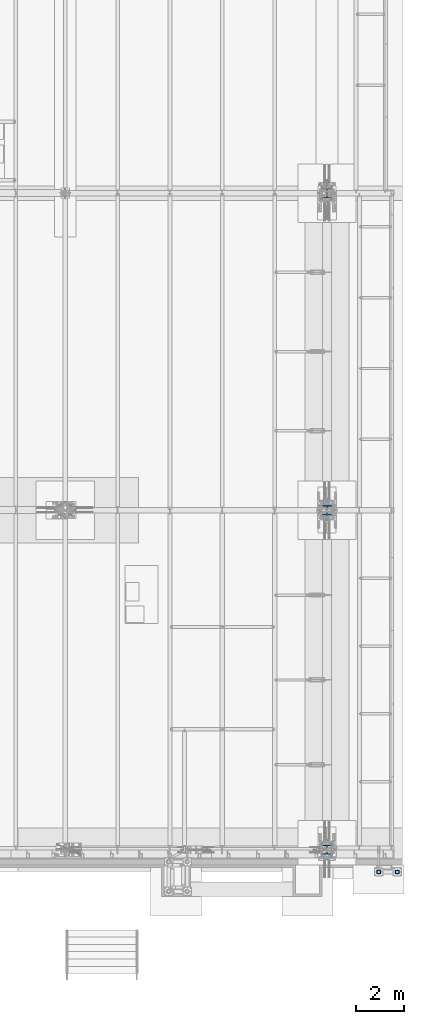
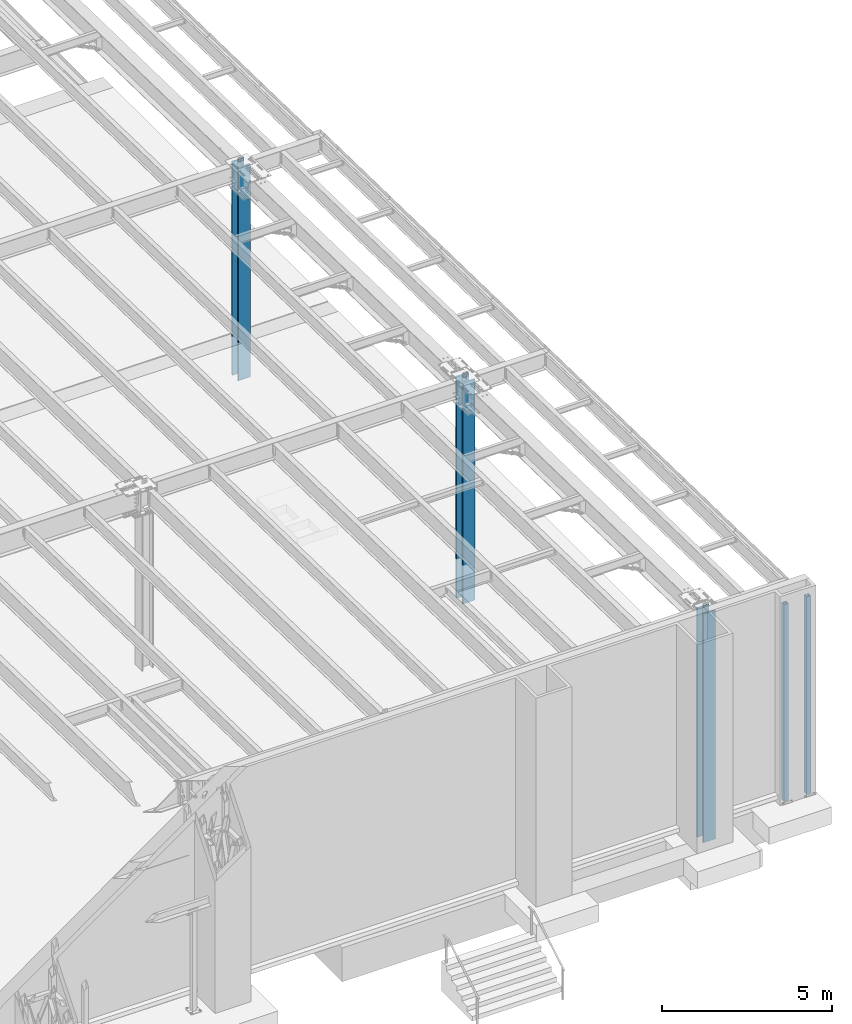
# One storey, part 911 of 1763: 5 columns, 4 elements without a shape of their own.
"""IFC2X3 building model written with IfcOpenShell, lengths in millimetres."""

from ifc_helpers import new_model, si_unit, frame, origin_with_axes, place, context, subcontext, project, spatial, faceted_brep, material, type_object, element, aggregate, save


model = new_model("IFC2X3")

# Units and contexts
model_context = context("Model", 3, precision=1e-05, world=origin_with_axes())
body_context = subcontext(model_context, "Body", "Model", "MODEL_VIEW")
ifc_project = project(units=[si_unit("LENGTHUNIT", "METRE", prefix="MILLI"), si_unit("AREAUNIT", "SQUARE_METRE"), si_unit("VOLUMEUNIT", "CUBIC_METRE"), si_unit("MASSUNIT", "GRAM", prefix="KILO"), si_unit("TIMEUNIT", "SECOND"), si_unit("PLANEANGLEUNIT", "RADIAN"), si_unit("SOLIDANGLEUNIT", "STERADIAN"), si_unit("THERMODYNAMICTEMPERATUREUNIT", "DEGREE_CELSIUS"), si_unit("LUMINOUSINTENSITYUNIT", "LUMEN")], contexts=[model_context])

# Site, building, storey
site_placement = place(None, origin_with_axes())
site = spatial("IfcSite", under=ifc_project, at=site_placement, CompositionType="ELEMENT")
building_placement = place(site_placement, origin_with_axes())
building = spatial("IfcBuilding", under=site, at=building_placement, Name="Undefined", CompositionType="ELEMENT")
storey_placement = place(building_placement, origin_with_axes())
storey = spatial("IfcBuildingStorey", under=building, at=storey_placement, Name="Undefined", CompositionType="ELEMENT", Elevation=0.0)

# Assembly, columns
assembly_1_placement = place(storey_placement, origin_with_axes())
assembly_1 = element("IfcElementAssembly", 1, at=assembly_1_placement, inside=storey, Name="FRAME", AssemblyPlace="NOTDEFINED", PredefinedType="RIGID_FRAME")
ifc_material_1 = material()
column_type_1 = type_object("IfcColumnType", Name="HSS6X6X5/8", PredefinedType="NOTDEFINED")
column_1_placement = place(assembly_1_placement, frame((-21097.3128611525, -14640.6432982799, 5029.2), z_axis=(0.0, 1.0, 0.0), x_axis=(0.0, 0.0, 1.0)))
column_1 = element("IfcColumn", 2, at=column_1_placement, type_object=column_type_1, material=ifc_material_1, Name="COLUMN", ObjectType="HSS6X6X5/8", context=body_context, shape_type="Brep", body=[
    faceted_brep([(63.4999999999973, 60.3249999999971, -60.3250000000007), (63.4999999999973, -60.3249999999971, -60.3250000000007), (7156.45, -60.3249999999971, -60.3250000000007), (7156.45, 60.3249999999971, -60.3250000000007), (63.4999999999973, -60.3249999999971, 60.3250000000007), (7156.45, -60.3249999999971, 60.3250000000007), (63.4999999999973, 60.3249999999971, 60.3250000000007), (7156.45, 60.3249999999971, 60.3250000000007), (63.4999999999973, 76.1999999999971, -76.2000000000007), (63.4999999999973, 76.1999999999971, 76.2000000000007), (7156.45, 76.1999999999971, 76.2000000000007), (7156.45, 76.1999999999971, -76.2000000000007), (63.4999999999973, -76.1999999999971, 76.2000000000007), (7156.45, -76.1999999999971, 76.2000000000007), (63.4999999999973, -76.1999999999971, -76.2000000000007), (7156.45, -76.1999999999971, -76.2000000000007)], [[[0, 1, 2, 3]], [[1, 4, 5, 2]], [[4, 6, 7, 5]], [[6, 0, 3, 7]], [[8, 9, 10, 11]], [[9, 12, 13, 10]], [[12, 14, 15, 13]], [[14, 8, 11, 15]], [[13, 15, 11, 10], [5, 7, 3, 2]], [[14, 12, 9, 8], [6, 4, 1, 0]]]),
])
column_2_placement = place(assembly_1_placement, frame((-21868.838056465, -14640.6432982799, 5029.2), z_axis=(0.0, 1.0, 0.0), x_axis=(0.0, 0.0, 1.0)))
column_2 = element("IfcColumn", 3, at=column_2_placement, type_object=column_type_1, material=ifc_material_1, Name="FRAME", ObjectType="HSS6X6X5/8", context=body_context, shape_type="Brep", body=[
    faceted_brep([(63.4999999999973, 60.3249999999971, -60.3250000000007), (63.4999999999973, -60.3249999999971, -60.3250000000007), (7156.45, -60.3249999999971, -60.3250000000007), (7156.45, 60.3249999999971, -60.3250000000007), (63.4999999999973, -60.3249999999971, 60.3250000000007), (7156.45, -60.3249999999971, 60.3250000000007), (63.4999999999973, 60.3249999999971, 60.3250000000007), (7156.45, 60.3249999999971, 60.3250000000007), (63.4999999999973, 76.1999999999971, -76.2000000000007), (63.4999999999973, 76.1999999999971, 76.2000000000007), (7156.45, 76.1999999999971, 76.2000000000007), (7156.45, 76.1999999999971, -76.2000000000007), (63.4999999999973, -76.1999999999971, 76.2000000000007), (7156.45, -76.1999999999971, 76.2000000000007), (63.4999999999973, -76.1999999999971, -76.2000000000007), (7156.45, -76.1999999999971, -76.2000000000007)], [[[0, 1, 2, 3]], [[1, 4, 5, 2]], [[4, 6, 7, 5]], [[6, 0, 3, 7]], [[8, 9, 10, 11]], [[9, 12, 13, 10]], [[12, 14, 15, 13]], [[14, 8, 11, 15]], [[13, 15, 11, 10], [5, 7, 3, 2]], [[14, 12, 9, 8], [6, 4, 1, 0]]]),
])
aggregate(assembly_1, [column_1, column_2])

# Assembly, column
assembly_2_placement = place(storey_placement, origin_with_axes())
assembly_2 = element("IfcElementAssembly", 4, at=assembly_2_placement, inside=storey, Name="COLUMN", AssemblyPlace="NOTDEFINED", PredefinedType="RIGID_FRAME")
ifc_material_2 = material(Name="STEEL/A992")
column_type_2 = type_object("IfcColumnType", Name="W14X257", PredefinedType="NOTDEFINED")
column_3_placement = place(assembly_2_placement, frame((-24027.8372736984, 13690.5999999999, 3810.0), z_axis=(0.0, 1.0, 0.0), x_axis=(0.0, 0.0, 1.0)))
column_3 = element("IfcColumn", 5, at=column_3_placement, type_object=column_type_2, material=ifc_material_2, Name="COLUMN", ObjectType="W14X257", context=body_context, shape_type="Brep", body=[
    faceted_brep([(129.096579002109, -203.200000000001, 207.9625), (129.096579002109, 203.200000000001, 207.9625), (101.600000000004, 203.200000000001, 160.3375), (101.600000000004, 15.0812499999993, 160.3375), (101.600000000004, -15.0812499999993, 160.3375), (101.600000000004, -203.200000000001, 160.3375), (101.600000000004, 15.0812499999993, 159.940498626711), (101.600000000004, -15.0812499999993, 159.940498626711), (152.400001525885, 15.0812499999993, 159.940498626711), (152.400001525885, -15.0812499999993, 159.940498626711), (152.400001525885, 15.0812499999993, 136.525499618532), (152.400001525885, -15.0812499999993, 136.525499618532), (151.674954102093, 15.0812499999993, 132.880440071236), (151.674954102093, -15.0812499999993, 132.880440071236), (149.610193728417, 15.0812499999993, 129.79030779747), (149.610193728417, -15.0812499999993, 129.79030779747), (146.52006145465, 15.0812499999993, 127.725547423794), (146.52006145465, -15.0812499999993, 127.725547423794), (142.875001907355, 15.0812499999993, 127.000500000002), (142.875001907355, -15.0812499999993, 127.000500000002), (101.600000000004, 15.0812499999993, 127.000500000002), (131.762500381475, -15.0812503814595, 127.000500000002), (101.600000000004, 15.0812499999993, -127.000499999998), (131.762500381475, -15.0812499999993, -127.000499999998), (142.875000381476, 15.0812499999993, -127.000499999998), (142.875000381476, -15.0812499999993, -127.000499999998), (146.520059928771, 15.0812499999993, -127.72554742379), (146.520059928771, -15.0812499999993, -127.72554742379), (149.610192202538, 15.0812499999993, -129.790307797466), (149.610192202538, -15.0812499999993, -129.790307797466), (151.674952576214, 15.0812499999993, -132.880440071232), (151.674952576214, -15.0812499999993, -132.880440071232), (152.400000000006, 15.0812499999993, -136.525499618529), (152.400000000006, -15.0812499999993, -136.525499618529), (152.400000000006, 15.0812499999993, -159.940498626707), (152.400000000006, -15.0812499999993, -159.940498626707), (101.600000000004, 15.0812499999993, -159.940498626707), (101.600000000004, -15.0812499999993, -159.940498626707), (101.600000000004, 15.0812499999993, -160.3375), (101.600000000004, -15.0812499999993, -160.3375), (129.096585718344, -203.200000000001, -207.9625), (101.600000000004, -203.200000000001, -160.3375), (101.600000000004, 203.200000000001, -160.3375), (129.096585718344, 203.200000000001, -207.9625), (7797.50462375373, -203.200000000001, -207.9625), (7796.50897368764, -203.200000000001, -160.3375), (7796.50897368764, -15.0812499999993, -160.3375), (7789.80492990931, -15.0812499999993, 160.3375), (7789.80492990931, -203.200000000001, 160.3375), (7788.80927984322, -203.200000000001, 207.9625), (7788.80927984322, 203.200000000001, 207.9625), (7789.80492990931, 203.200000000001, 160.3375), (7789.80492990931, 15.0812499999993, 160.3375), (7796.50897368764, 15.0812499999993, -160.3375), (7796.50897368764, 203.200000000001, -160.3375), (7797.50462375373, 203.200000000001, -207.9625)], [[[0, 1, 2, 3, 4, 5]], [[6, 7, 4, 3]], [[8, 9, 7, 6]], [[9, 8, 10, 11]], [[11, 10, 12, 13]], [[13, 12, 14, 15]], [[15, 14, 16, 17]], [[17, 16, 18, 19]], [[19, 18, 20, 21]], [[21, 20, 22, 23]], [[24, 25, 23, 22]], [[25, 24, 26, 27]], [[27, 26, 28, 29]], [[29, 28, 30, 31]], [[31, 30, 32, 33]], [[33, 32, 34, 35]], [[35, 34, 36, 37]], [[38, 39, 37, 36]], [[40, 41, 39, 38, 42, 43]], [[41, 40, 44, 45]], [[39, 41, 45, 46]], [[4, 7, 9, 11, 13, 15, 17, 19, 21, 23, 25, 27, 29, 31, 33, 35, 37, 39, 46, 47]], [[5, 4, 47, 48]], [[0, 5, 48, 49]], [[1, 0, 49, 50]], [[2, 1, 50, 51]], [[3, 2, 51, 52]], [[38, 36, 34, 32, 30, 28, 26, 24, 22, 20, 18, 16, 14, 12, 10, 8, 6, 3, 52, 53]], [[42, 38, 53, 54]], [[43, 42, 54, 55]], [[40, 43, 55, 44]], [[54, 53, 52, 51, 50, 49, 48, 47, 46, 45, 44, 55]]]),
])
aggregate(assembly_2, [column_3])

assembly_3_placement = place(storey_placement, origin_with_axes())
assembly_3 = element("IfcElementAssembly", 6, at=assembly_3_placement, inside=storey, Name="COLUMN", AssemblyPlace="NOTDEFINED", PredefinedType="RIGID_FRAME")
column_4_placement = place(assembly_3_placement, frame((-24027.8372736984, -13716.0000000001, 3810.0), z_axis=(0.0, 1.0, 0.0), x_axis=(0.0, 0.0, 1.0)))
column_4 = element("IfcColumn", 7, at=column_4_placement, type_object=column_type_2, material=ifc_material_2, Name="COLUMN", ObjectType="W14X257", context=body_context, shape_type="Brep", body=[
    faceted_brep([(129.096579002109, -203.200000000001, 207.9625), (129.096579002109, 203.200000000001, 207.9625), (101.600000000004, 203.200000000001, 160.3375), (101.600000000004, 15.0812499999993, 160.3375), (101.600000000004, -15.0812499999993, 160.3375), (101.600000000004, -203.200000000001, 160.3375), (101.600000000004, 15.0812499999993, 159.940498626711), (101.600000000004, -15.0812499999993, 159.940498626711), (152.400001525885, 15.0812499999993, 159.940498626711), (152.400001525885, -15.0812499999993, 159.940498626711), (152.400001525885, 15.0812499999993, 136.525499618532), (152.400001525885, -15.0812499999993, 136.525499618532), (151.674954102093, 15.0812499999993, 132.880440071236), (151.674954102093, -15.0812499999993, 132.880440071236), (149.610193728417, 15.0812499999993, 129.79030779747), (149.610193728417, -15.0812499999993, 129.79030779747), (146.52006145465, 15.0812499999993, 127.725547423794), (146.52006145465, -15.0812499999993, 127.725547423794), (142.875001907355, 15.0812499999993, 127.000500000002), (142.875001907355, -15.0812499999993, 127.000500000002), (101.600000000004, 15.0812499999993, 127.000500000002), (131.762500381475, -15.0812503814595, 127.000500000002), (101.600000000004, 15.0812499999993, -127.000499999998), (131.762500381475, -15.0812499999993, -127.000499999998), (142.875000381476, 15.0812499999993, -127.000499999998), (142.875000381476, -15.0812499999993, -127.000499999998), (146.520059928771, 15.0812499999993, -127.72554742379), (146.520059928771, -15.0812499999993, -127.72554742379), (149.610192202538, 15.0812499999993, -129.790307797466), (149.610192202538, -15.0812499999993, -129.790307797466), (151.674952576214, 15.0812499999993, -132.880440071232), (151.674952576214, -15.0812499999993, -132.880440071232), (152.400000000006, 15.0812499999993, -136.525499618529), (152.400000000006, -15.0812499999993, -136.525499618529), (152.400000000006, 15.0812499999993, -159.940498626707), (152.400000000006, -15.0812499999993, -159.940498626707), (101.600000000004, 15.0812499999993, -159.940498626707), (101.600000000004, -15.0812499999993, -159.940498626707), (101.600000000004, 15.0812499999993, -160.3375), (101.600000000004, -15.0812499999993, -160.3375), (129.096585718344, -203.200000000001, -207.9625), (101.600000000004, -203.200000000001, -160.3375), (101.600000000004, 203.200000000001, -160.3375), (129.096585718344, 203.200000000001, -207.9625), (8354.5831008732, -203.200000000001, -207.962499994344), (8353.5874573364, -203.200000000001, -160.337499994346), (8353.5874573364, -15.0812499999993, -160.337499994346), (8346.88345752195, -15.0812499999993, 160.337500005651), (8346.88345752195, -203.200000000001, 160.337500005651), (8345.88781398516, -203.200000000001, 207.962500005649), (8345.88781398516, 203.200000000001, 207.962500005649), (8346.88345752195, 203.200000000001, 160.337500005651), (8346.88345752195, 15.0812499999993, 160.337500005651), (8353.5874573364, 15.0812499999993, -160.337499994346), (8353.5874573364, 203.200000000001, -160.337499994346), (8354.5831008732, 203.200000000001, -207.962499994344)], [[[0, 1, 2, 3, 4, 5]], [[6, 7, 4, 3]], [[8, 9, 7, 6]], [[9, 8, 10, 11]], [[11, 10, 12, 13]], [[13, 12, 14, 15]], [[15, 14, 16, 17]], [[17, 16, 18, 19]], [[19, 18, 20, 21]], [[21, 20, 22, 23]], [[24, 25, 23, 22]], [[25, 24, 26, 27]], [[27, 26, 28, 29]], [[29, 28, 30, 31]], [[31, 30, 32, 33]], [[33, 32, 34, 35]], [[35, 34, 36, 37]], [[38, 39, 37, 36]], [[40, 41, 39, 38, 42, 43]], [[41, 40, 44, 45]], [[39, 41, 45, 46]], [[4, 7, 9, 11, 13, 15, 17, 19, 21, 23, 25, 27, 29, 31, 33, 35, 37, 39, 46, 47]], [[5, 4, 47, 48]], [[0, 5, 48, 49]], [[1, 0, 49, 50]], [[2, 1, 50, 51]], [[3, 2, 51, 52]], [[38, 36, 34, 32, 30, 28, 26, 24, 22, 20, 18, 16, 14, 12, 10, 8, 6, 3, 52, 53]], [[42, 38, 53, 54]], [[43, 42, 54, 55]], [[40, 43, 55, 44]], [[54, 53, 52, 51, 50, 49, 48, 47, 46, 45, 44, 55]]]),
])
aggregate(assembly_3, [column_4])

assembly_4_placement = place(storey_placement, origin_with_axes())
assembly_4 = element("IfcElementAssembly", 8, at=assembly_4_placement, inside=storey, Name="COLUMN", AssemblyPlace="NOTDEFINED", PredefinedType="RIGID_FRAME")
column_type_3 = type_object("IfcColumnType", Name="W14X342", PredefinedType="NOTDEFINED")
column_5_placement = place(assembly_4_placement, frame((-24027.8372736984, 457.199999999998, 3810.0), z_axis=(0.0, 1.0, 0.0), x_axis=(0.0, 0.0, 1.0)))
column_5 = element("IfcColumn", 9, at=column_5_placement, type_object=column_type_3, material=ifc_material_2, Name="COLUMN", ObjectType="W14X342", context=body_context, shape_type="Brep", body=[
    faceted_brep([(138.2615884844, -207.962500000001, 222.25), (138.2615884844, 207.962500000001, 222.25), (101.600000000004, 207.962500000001, 158.75), (101.600000000004, 19.84375, 158.75), (101.600000000004, -19.84375, 158.75), (101.600000000004, -207.962500000001, 158.75), (101.600000000004, 19.84375, 158.352998945448), (101.600000000004, -19.84375, 158.352998945448), (152.400001525886, 19.84375, 158.353000640869), (152.400001525886, -19.84375, 158.353000640869), (152.400001525886, 19.84375, 136.52499961853), (152.400001525886, -19.84375, 136.52499961853), (151.674954102094, 19.84375, 132.879940071235), (151.674954102094, -19.84375, 132.879940071235), (149.610193728417, 19.84375, 129.789807797468), (149.610193728417, -19.84375, 129.789807797468), (146.520061454651, 19.84375, 127.725047423792), (146.520061454651, -19.84375, 127.725047423792), (142.875001907355, 19.84375, 127.0), (142.875001907355, -19.84375, 127.0), (101.600000000004, 19.84375, 127.0), (141.287500000008, -19.84375, 127.0), (101.600000000004, 19.84375, -127.0), (141.287500000008, -19.84375, -127.0), (142.874999955001, 19.84375, -127.0), (142.874999955001, -19.84375, -127.0), (146.5200596008, 19.84375, -127.725047464594), (146.5200596008, -19.84375, -127.725047464594), (149.610191926845, 19.84375, -129.78980794825), (149.610191926845, -19.84375, -129.78980794825), (151.674952272143, 19.84375, -132.879940366744), (151.674952272143, -19.84375, -132.879940366744), (152.399999573532, 19.84375, -136.525000045005), (152.399999573532, -19.84375, -136.525000045005), (152.399998596198, 19.84375, -158.353000640869), (152.399998596198, -19.84375, -158.353000640869), (101.600000000004, 19.84375, -158.352998945448), (101.600000000004, -19.84375, -158.352998945448), (101.600000000004, 19.84375, -158.75), (101.600000000004, -19.84375, -158.75), (138.261593562515, -207.962500000001, -222.25), (101.600000000004, -207.962500000001, -158.75), (101.600000000004, 207.962500000001, -158.75), (138.261593562515, 207.962500000001, -222.25), (8077.63702313808, -207.962500000001, -222.25), (8076.30949384769, -207.962500000001, -158.75), (8076.30949384769, -19.84375, -158.75), (8069.67184739572, -19.84375, 158.75), (8069.67184739572, -207.962500000001, 158.75), (8068.34431810533, -207.962500000001, 222.25), (8068.34431810533, 207.962500000001, 222.25), (8069.67184739572, 207.962500000001, 158.75), (8069.67184739572, 19.84375, 158.75), (8076.30949384769, 19.84375, -158.75), (8076.30949384769, 207.962500000001, -158.75), (8077.63702313808, 207.962500000001, -222.25)], [[[0, 1, 2, 3, 4, 5]], [[6, 7, 4, 3]], [[8, 9, 7, 6]], [[9, 8, 10, 11]], [[11, 10, 12, 13]], [[13, 12, 14, 15]], [[15, 14, 16, 17]], [[17, 16, 18, 19]], [[19, 18, 20, 21]], [[21, 20, 22, 23]], [[24, 25, 23, 22]], [[25, 24, 26, 27]], [[27, 26, 28, 29]], [[29, 28, 30, 31]], [[31, 30, 32, 33]], [[33, 32, 34, 35]], [[35, 34, 36, 37]], [[38, 39, 37, 36]], [[40, 41, 39, 38, 42, 43]], [[41, 40, 44, 45]], [[39, 41, 45, 46]], [[4, 7, 9, 11, 13, 15, 17, 19, 21, 23, 25, 27, 29, 31, 33, 35, 37, 39, 46, 47]], [[5, 4, 47, 48]], [[0, 5, 48, 49]], [[1, 0, 49, 50]], [[2, 1, 50, 51]], [[3, 2, 51, 52]], [[38, 36, 34, 32, 30, 28, 26, 24, 22, 20, 18, 16, 14, 12, 10, 8, 6, 3, 52, 53]], [[42, 38, 53, 54]], [[43, 42, 54, 55]], [[40, 43, 55, 44]], [[54, 53, 52, 51, 50, 49, 48, 47, 46, 45, 44, 55]]]),
])
aggregate(assembly_4, [column_5])

save(model, "model.ifc")
